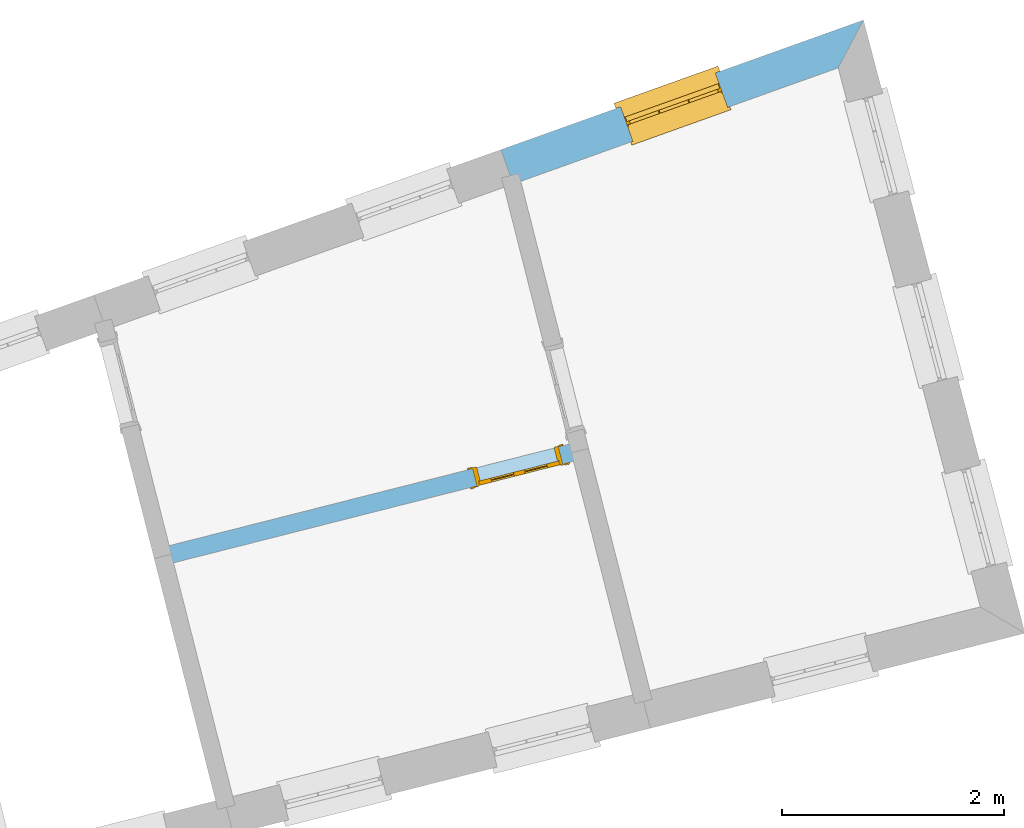
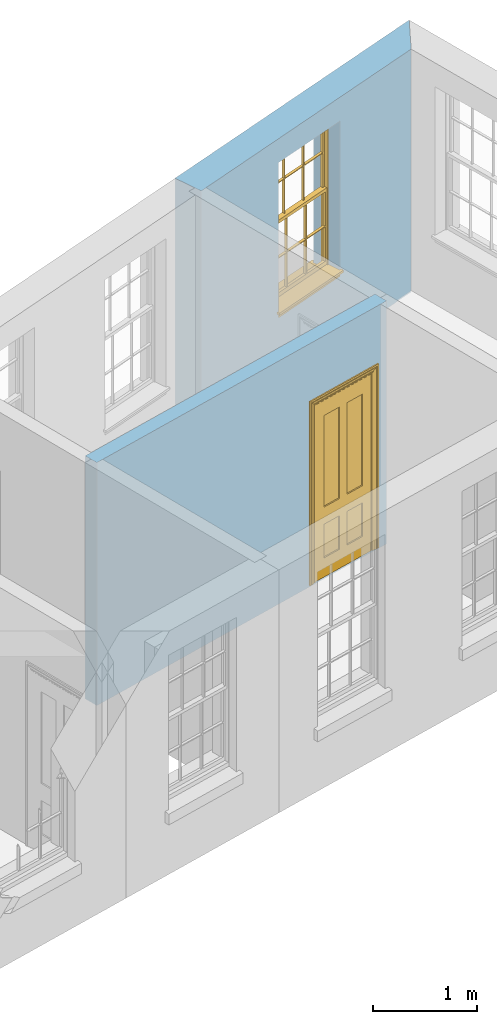
# One storey, part 8 of 11: 1 door, 1 window, 2 openings, plus 2 elements that do not belong to this part.
"""IFC2X3 building model written with IfcOpenShell, lengths in metres."""

from ifc_helpers import new_model, si_unit, frame, origin, place, context, subcontext, project, spatial, polyline, outline, extrude, faceted_brep, material, layer, layer_set, layer_usage, element, fill, save


model = new_model("IFC2X3")

# Units and contexts
model_context = context("Model", 3, world=origin())
body_context = subcontext(model_context, "Body", "Model", "MODEL_VIEW")
ifc_project = project(units=[si_unit("PLANEANGLEUNIT", "RADIAN"), si_unit("MASSUNIT", "GRAM", prefix="KILO"), si_unit("FORCEUNIT", "NEWTON", prefix="KILO"), si_unit("LENGTHUNIT", "METRE")], contexts=[model_context])

# Site, building, storey
site_placement = place(None, origin())
site = spatial("IfcSite", under=ifc_project, at=site_placement, CompositionType="ELEMENT")
building_placement = place(None, origin())
building = spatial("IfcBuilding", under=site, at=building_placement, Name="Building plot-13", CompositionType="ELEMENT")
storey_placement = place(None, frame((0.0, 0.0, 6.7)))
storey = spatial("IfcBuildingStorey", under=building, at=storey_placement, Name="Floor 1", CompositionType="ELEMENT", Elevation=6.7)

# Wall, opening, window
ifc_material_1 = material(Name="Masonry")
ifc_layer_1 = layer(ifc_material_1, 0.33, ventilated=False)
ifc_layer_set_1 = layer_set([ifc_layer_1], Name="My Wall")
ifc_layer_usage_1 = layer_usage(ifc_layer_set_1, "AXIS2", "NEGATIVE", 0.08)
wall_1_placement = place(storey_placement, origin())
wall_1 = element("IfcWallStandardCase", 1, at=wall_1_placement, inside=storey, material=ifc_layer_usage_1, Name="exterior", context=body_context, shape_type="SweptSolid", body=[
    extrude(outline(polyline([(78.699089450727, 52.1144212259562), (78.9265356735152, 52.5462115674965), (75.6540271002417, 51.3760559996695), (75.765136209946, 51.0653233722537), (78.699089450727, 52.1144212259562)])), origin(), (0.0, 0.0, 1.0), 2.85),
])
opening_1_placement = place(storey_placement, frame((0.0, 0.0, 0.75)))
opening_1 = element("IfcOpeningElement", 2, at=opening_1_placement, cuts=wall_1, Name="Opening", ObjectType="Opening", context=body_context, shape_type="SweptSolid", body=[
    extrude(outline(polyline([(77.5904751108561, 52.0684744825221), (76.7336063504065, 51.7620826951557), (76.8447154601108, 51.4513500677399), (77.7015842205604, 51.7577418551063), (77.5904751108561, 52.0684744825221)])), origin(), (0.0, 0.0, 1.0), 1.82),
])
window_placement = place(storey_placement, frame((77.6746486788139, 51.833070976904, 0.75), z_axis=(0.0, 0.0, 1.0), x_axis=(-0.856868760449601, -0.306391787366394, 0.0)))
window = element("IfcWindow", 3, at=window_placement, inside=storey, Name="bedroom outside window", OverallHeight=1.82, OverallWidth=0.91, context=body_context, shape_type="Brep", held_by="IfcProductRepresentation", body=[
    faceted_brep([(0.033125, -0.105, 0.975209), (0.01, -0.105, 0.975209), (0.033125, -0.105, 1.376042), (0.876875, -0.105, 0.975209), (0.876875, -0.105, 1.376042), (0.9, -0.105, 0.975209), (0.876875, -0.105, 1.386042), (0.876875, -0.105, 1.786875), (0.9, -0.105, 1.81), (0.033125, -0.105, 1.786875), (0.033125, -0.105, 1.386042), (0.01, -0.105, 1.81), (0.876875, -0.135, 1.376042), (0.876875, -0.135, 0.975209), (0.9, -0.135, 0.937083), (0.033125, -0.135, 1.786875), (0.01, -0.135, 1.81), (0.033125, -0.135, 1.386042), (0.01, -0.135, 0.937083), (0.033125, -0.135, 0.975209), (0.033125, -0.135, 1.376042), (0.876875, -0.135, 1.786875), (0.876875, -0.135, 1.386042), (0.9, -0.135, 1.81), (0.033125, -0.105, 0.937083), (0.01, -0.105, 0.937083), (0.033125, -0.105, 0.53625), (0.876875, -0.105, 0.937083), (0.876875, -0.105, 0.53625), (0.9, -0.105, 0.937083), (0.876875, -0.105, 0.52625), (0.876875, -0.105, 0.125417), (0.9, -0.105, 0.077167), (0.033125, -0.105, 0.125417), (0.033125, -0.105, 0.52625), (0.01, -0.105, 0.077167), (-0.0425, -0.25, 0.01), (-0.0425, -0.3, 0.001667), (0.0, -0.25, 0.01), (0.9525, -0.25, 0.01), (0.91, -0.25, 0.01), (0.9525, -0.3, 0.001667), (-0.02, 0.08, 0.077167), (0.0, 0.08, 0.077167), (-0.02, 0.11, 0.077167), (0.0, -0.06, 0.077167), (0.01, -0.06, 0.077167), (0.91, -0.06, 0.077167), (0.91, 0.08, 0.077167), (0.9, -0.06, 0.077167), (0.93, 0.08, 0.077167), (0.93, 0.11, 0.077167), (0.01, -0.075, 0.975209), (0.9, -0.075, 0.975209), (0.876875, -0.075, 0.125417), (0.876875, -0.075, 0.52625), (0.9, -0.075, 0.077167), (0.876875, -0.075, 0.53625), (0.876875, -0.075, 0.937083), (0.033125, -0.075, 0.125417), (0.01, -0.075, 0.077167), (0.033125, -0.075, 0.52625), (0.033125, -0.075, 0.937083), (0.033125, -0.075, 0.53625), (-0.02, 0.08, 0.052167), (-0.02, 0.11, 0.052167), (0.93, 0.11, 0.052167), (0.93, 0.08, 0.052167), (0.91, 0.08, 0.052167), (0.0, 0.08, 0.052167), (0.91, -0.15, 0.026667), (0.0, -0.15, 0.026667), (-0.0425, -0.3, -0.123333), (0.9525, -0.3, -0.123333), (-0.0425, -0.25, -0.123333), (0.9525, -0.25, -0.123333), (0.01, -0.06, 1.81), (0.9, -0.06, 1.81), (0.0, -0.06, 1.82), (0.91, -0.06, 1.82), (0.01, -0.15, 0.077167), (0.9, -0.15, 0.077167), (0.592292, -0.105, 0.125417), (0.592292, -0.075, 0.125417), (0.317708, -0.075, 0.125417), (0.317708, -0.105, 0.125417), (0.592292, -0.105, 0.53625), (0.317708, -0.105, 0.53625), (0.317708, -0.105, 0.52625), (0.592292, -0.105, 0.52625), (0.592292, -0.075, 0.53625), (0.317708, -0.075, 0.53625), (0.592292, -0.135, 1.386042), (0.592292, -0.105, 1.386042), (0.317708, -0.105, 1.386042), (0.317708, -0.135, 1.386042), (0.317708, -0.135, 1.376042), (0.592292, -0.135, 1.376042), (0.317708, -0.105, 1.376042), (0.592292, -0.105, 1.376042), (0.602292, -0.135, 1.376042), (0.592292, -0.135, 0.975209), (0.602292, -0.135, 0.975209), (0.602292, -0.105, 0.975209), (0.592292, -0.105, 0.975209), (0.602292, -0.105, 1.376042), (0.602292, -0.075, 0.53625), (0.602292, -0.105, 0.53625), (0.317708, -0.075, 0.52625), (0.307708, -0.075, 0.125417), (0.307708, -0.075, 0.52625), (0.602292, -0.075, 0.52625), (0.602292, -0.075, 0.125417), (0.592292, -0.075, 0.52625), (0.307708, -0.075, 0.53625), (0.317708, -0.075, 0.937083), (0.307708, -0.075, 0.937083), (0.602292, -0.075, 0.937083), (0.592292, -0.075, 0.937083), (0.307708, -0.105, 0.52625), (0.307708, -0.105, 0.125417), (0.307708, -0.105, 0.53625), (0.307708, -0.105, 0.937083), (0.592292, -0.105, 0.937083), (0.317708, -0.105, 0.937083), (0.602292, -0.105, 0.937083), (0.602292, -0.105, 0.52625), (0.602292, -0.105, 0.125417), (0.307708, -0.135, 1.386042), (0.307708, -0.135, 1.376042), (0.307708, -0.135, 0.975209), (0.317708, -0.135, 0.975209), (0.317708, -0.135, 1.786875), (0.307708, -0.135, 1.786875), (0.602292, -0.135, 1.786875), (0.592292, -0.135, 1.786875), (0.602292, -0.135, 1.386042), (0.602292, -0.105, 1.386042), (0.307708, -0.105, 1.386042), (0.307708, -0.105, 1.786875), (0.317708, -0.105, 1.786875), (0.592292, -0.105, 1.786875), (0.602292, -0.105, 1.786875), (0.307708, -0.105, 1.376042), (0.317708, -0.105, 0.975209), (0.307708, -0.105, 0.975209), (0.91, -0.15, 1.82), (0.9, -0.15, 1.81), (0.01, -0.15, 1.81), (0.0, -0.15, 1.82), (0.91, -0.25, 0.0), (0.0, -0.25, 0.0), (0.91, 0.08, 0.0), (0.0, 0.08, 0.0)], [[[0, 1, 2]], [[3, 4, 5]], [[6, 7, 8]], [[9, 10, 11]], [[12, 13, 14]], [[15, 16, 17]], [[18, 19, 20]], [[21, 22, 23]], [[24, 25, 26]], [[27, 28, 29]], [[30, 31, 32]], [[33, 34, 35]], [[14, 27, 29]], [[25, 24, 18]], [[36, 37, 38]], [[39, 40, 41]], [[42, 43, 44]], [[45, 46, 43]], [[47, 48, 49]], [[50, 51, 48]], [[1, 0, 52]], [[5, 53, 3]], [[54, 55, 56]], [[57, 58, 53]], [[59, 60, 61]], [[62, 63, 52]], [[48, 43, 46, 49]], [[51, 44, 43, 48]], [[64, 42, 44, 65]], [[65, 44, 51, 66]], [[66, 51, 50, 67]], [[65, 66, 68, 69]], [[60, 56, 49, 46]], [[70, 71, 38, 40]], [[37, 41, 40, 38]], [[37, 72, 73, 41]], [[74, 75, 73, 72]], [[8, 11, 76, 77]], [[76, 78, 79, 77]], [[32, 35, 80, 81]], [[81, 80, 71, 70]], [[82, 83, 84, 85]], [[86, 87, 88, 89]], [[86, 90, 91, 87]], [[92, 93, 94, 95]], [[92, 95, 96, 97]], [[96, 98, 99, 97]], [[100, 97, 101, 102]], [[103, 104, 99, 105]], [[97, 99, 104, 101]], [[102, 103, 105, 100]], [[28, 57, 106, 107]], [[108, 84, 109, 110]], [[111, 112, 83, 113]], [[114, 110, 61, 63]], [[90, 113, 108, 91]], [[115, 91, 114, 116]], [[117, 106, 90, 118]], [[111, 106, 57, 55]], [[119, 110, 109, 120]], [[34, 61, 110, 119]], [[89, 113, 83, 82]], [[88, 108, 113, 89]], [[85, 84, 108, 88]], [[121, 114, 63, 26]], [[122, 116, 114, 121]], [[123, 118, 90, 86]], [[87, 91, 115, 124]], [[107, 106, 117, 125]], [[126, 111, 55, 30]], [[127, 112, 111, 126]], [[126, 30, 28, 107]], [[88, 119, 120, 85]], [[126, 89, 82, 127]], [[125, 123, 86, 107]], [[121, 26, 34, 119]], [[124, 122, 121, 87]], [[128, 17, 20, 129]], [[96, 129, 130, 131]], [[132, 133, 128, 95]], [[134, 135, 92, 136]], [[100, 12, 22, 136]], [[137, 6, 4, 105]], [[94, 138, 139, 140]], [[137, 93, 141, 142]], [[99, 98, 94, 93]], [[143, 2, 10, 138]], [[144, 145, 143, 98]], [[129, 143, 145, 130]], [[20, 2, 143, 129]], [[131, 144, 98, 96]], [[128, 138, 10, 17]], [[133, 139, 138, 128]], [[135, 141, 93, 92]], [[95, 94, 140, 132]], [[22, 6, 137, 136]], [[136, 137, 142, 134]], [[100, 105, 4, 12]], [[107, 86, 89, 126]], [[106, 111, 113, 90]], [[91, 108, 110, 114]], [[87, 121, 119, 88]], [[97, 100, 136, 92]], [[129, 96, 95, 128]], [[98, 143, 138, 94]], [[105, 99, 93, 137]], [[131, 101, 104, 144]], [[124, 115, 118, 123]], [[132, 140, 141, 135]], [[120, 109, 59, 33]], [[15, 9, 139, 133]], [[134, 142, 7, 21]], [[31, 54, 112, 127]], [[36, 74, 72, 37]], [[39, 41, 73, 75]], [[18, 14, 101, 131]], [[23, 16, 132, 135]], [[83, 56, 60, 84]], [[52, 53, 118, 115]], [[53, 52, 144, 104]], [[11, 8, 141, 140]], [[14, 18, 124, 123]], [[2, 1, 11, 10]], [[8, 5, 4, 6]], [[57, 53, 56, 55]], [[60, 52, 63, 61]], [[26, 25, 35, 34]], [[32, 29, 28, 30]], [[14, 23, 22, 12]], [[18, 20, 17, 16]], [[19, 0, 2, 20]], [[17, 10, 9, 15]], [[12, 4, 3, 13]], [[21, 7, 6, 22]], [[27, 58, 57, 28]], [[30, 55, 54, 31]], [[33, 59, 61, 34]], [[26, 63, 62, 24]], [[5, 8, 77, 53]], [[76, 11, 1, 52]], [[46, 45, 78, 76]], [[49, 77, 79, 47]], [[70, 146, 147, 81]], [[71, 80, 148, 149]], [[19, 130, 145, 0]], [[102, 13, 3, 103]], [[116, 122, 24, 62]], [[29, 32, 81, 14]], [[80, 35, 25, 18]], [[60, 46, 76, 52]], [[77, 49, 56, 53]], [[23, 14, 81, 147]], [[16, 148, 80, 18]], [[35, 85, 120]], [[120, 33, 35]], [[127, 82, 32]], [[32, 31, 127]], [[32, 82, 85, 35]], [[102, 101, 14]], [[14, 13, 102]], [[18, 131, 130]], [[130, 19, 18]], [[134, 21, 23]], [[23, 135, 134]], [[16, 15, 133]], [[133, 132, 16]], [[11, 140, 139]], [[139, 9, 11]], [[142, 141, 8]], [[8, 7, 142]], [[23, 147, 148, 16]], [[146, 149, 148, 147]], [[52, 115, 116]], [[116, 62, 52]], [[118, 53, 117]], [[58, 117, 53]], [[27, 125, 117, 58]], [[56, 83, 112]], [[112, 54, 56]], [[109, 84, 60]], [[60, 59, 109]], [[125, 27, 14]], [[14, 123, 125]], [[122, 124, 18]], [[18, 24, 122]], [[145, 144, 52]], [[52, 0, 145]], [[103, 3, 53]], [[53, 104, 103]], [[79, 78, 149, 146]], [[78, 45, 71, 149]], [[146, 70, 47, 79]], [[150, 75, 74, 151]], [[68, 66, 67]], [[48, 68, 67, 50]], [[69, 64, 65]], [[42, 64, 69, 43]], [[69, 68, 152, 153]], [[70, 68, 48, 47]], [[150, 152, 68, 70]], [[43, 69, 71, 45]], [[69, 153, 151, 71]], [[152, 150, 151, 153]], [[38, 151, 74, 36]], [[71, 151, 38]], [[39, 75, 150, 40]], [[40, 150, 70]]]),
])
fill(opening_1, window)

# Wall, opening, door
ifc_material_2 = material(Name="Masonry")
ifc_layer_2 = layer(ifc_material_2, 0.16, ventilated=False)
ifc_layer_set_2 = layer_set([ifc_layer_2], Name="My Wall")
ifc_layer_usage_2 = layer_usage(ifc_layer_set_2, "AXIS2", "NEGATIVE", 0.08)
wall_2_placement = place(storey_placement, origin())
wall_2 = element("IfcWallStandardCase", 4, at=wall_2_placement, inside=storey, material=ifc_layer_usage_2, Name="interior", context=body_context, shape_type="SweptSolid", body=[
    extrude(outline(polyline([(76.3872594352377, 48.5815460629626), (76.3479245240301, 48.736635600844), (72.5821025731174, 47.7815210645155), (72.621437484325, 47.6264315266341), (76.3872594352377, 48.5815460629626)])), origin(), (0.0, 0.0, 1.0), 2.85),
])
opening_2_placement = place(storey_placement, frame((0.0, 0.0, 0.0199999999999996)))
opening_2 = element("IfcOpeningElement", 5, at=opening_2_placement, cuts=wall_2, Name="Opening", ObjectType="Opening", context=body_context, shape_type="SweptSolid", body=[
    extrude(outline(polyline([(76.1734487939134, 48.6923838257354), (75.3980011045061, 48.495709269697), (75.4373360157138, 48.3406197318156), (76.2127837051211, 48.5372942878539), (76.1734487939134, 48.6923838257354)])), origin(), (0.0, 0.0, 1.0), 2.1),
])
door_placement = place(storey_placement, frame((76.1931162495173, 48.6148390567947, 0.0199999999999996), z_axis=(0.0, 0.0, 1.0), x_axis=(-0.775447689407301, -0.19667455603836, 0.0)))
door = element("IfcDoor", 6, at=door_placement, inside=storey, Name="toilet inside door", OverallHeight=2.1, OverallWidth=0.8, context=body_context, shape_type="Brep", held_by="IfcProductRepresentation", body=[
    faceted_brep([(0.773, 0.08, 1.895), (0.66, 0.08, 1.895), (0.66, 0.08, 2.073), (0.773, 0.08, 2.073), (0.773, 0.08, 0.82), (0.66, 0.08, 0.82), (0.45, 0.08, 1.895), (0.45, 0.08, 2.073), (0.773, 0.08, 0.62), (0.66, 0.08, 0.62), (0.66, 0.065, 0.82), (0.66, 0.065, 1.895), (0.45, 0.065, 1.895), (0.35, 0.08, 1.895), (0.35, 0.08, 2.073), (0.773, 0.08, 0.225), (0.66, 0.08, 0.225), (0.45, 0.08, 0.62), (0.45, 0.08, 0.82), (0.45, 0.065, 0.82), (0.35, 0.08, 0.82), (0.14, 0.08, 2.073), (0.14, 0.08, 1.895), (0.773, 0.08, 0.0), (0.66, 0.08, 0.0), (0.66, 0.065, 0.225), (0.66, 0.065, 0.62), (0.45, 0.065, 0.62), (0.35, 0.08, 0.62), (0.35, 0.065, 0.82), (0.35, 0.065, 1.895), (0.14, 0.065, 1.895), (0.027, 0.08, 2.073), (0.027, 0.08, 1.895), (0.773, 0.042, 0.0), (0.66, 0.042, 0.0), (0.45, 0.08, 0.0), (0.45, 0.08, 0.225), (0.45, 0.065, 0.225), (0.35, 0.08, 0.225), (0.14, 0.08, 0.82), (0.14, 0.08, 0.62), (0.14, 0.065, 0.82), (0.027, 0.08, 0.82), (0.773, 0.042, 0.225), (0.66, 0.042, 0.225), (0.45, 0.042, 0.0), (0.35, 0.08, 0.0), (0.35, 0.065, 0.225), (0.35, 0.065, 0.62), (0.14, 0.065, 0.62), (0.027, 0.08, 0.62), (0.773, 0.042, 0.62), (0.66, 0.042, 0.62), (0.45, 0.042, 0.225), (0.35, 0.042, 0.0), (0.14, 0.08, 0.225), (0.14, 0.08, 0.0), (0.14, 0.065, 0.225), (0.027, 0.08, 0.225), (0.773, 0.042, 0.82), (0.66, 0.042, 0.82), (0.66, 0.057, 0.62), (0.66, 0.057, 0.225), (0.45, 0.057, 0.225), (0.35, 0.042, 0.225), (0.14, 0.042, 0.0), (0.027, 0.08, 0.0), (0.773, 0.042, 1.895), (0.66, 0.042, 1.895), (0.45, 0.042, 0.62), (0.45, 0.042, 0.82), (0.45, 0.057, 0.62), (0.35, 0.042, 0.62), (0.14, 0.042, 0.225), (0.027, 0.042, 0.0), (0.773, 0.042, 2.073), (0.66, 0.042, 2.073), (0.66, 0.057, 1.895), (0.66, 0.057, 0.82), (0.45, 0.057, 0.82), (0.35, 0.042, 0.82), (0.35, 0.057, 0.62), (0.35, 0.057, 0.225), (0.14, 0.057, 0.225), (0.027, 0.042, 0.225), (0.45, 0.042, 1.895), (0.45, 0.042, 2.073), (0.45, 0.057, 1.895), (0.35, 0.042, 1.895), (0.14, 0.042, 0.82), (0.14, 0.042, 0.62), (0.14, 0.057, 0.62), (0.027, 0.042, 0.62), (0.35, 0.042, 2.073), (0.35, 0.057, 1.895), (0.35, 0.057, 0.82), (0.14, 0.057, 0.82), (0.027, 0.042, 0.82), (0.14, 0.042, 2.073), (0.14, 0.042, 1.895), (0.14, 0.057, 1.895), (0.027, 0.042, 1.895), (0.027, 0.042, 2.073), (0.02, 0.085, 0.0), (0.005, 0.09, 0.0), (0.005, 0.09, 2.095), (0.02, 0.085, 2.08), (0.02, 0.08, 0.0), (0.0, 0.085, 0.0), (0.0, 0.085, 2.1), (0.795, 0.09, 2.095), (0.78, 0.085, 2.08), (0.02, 0.08, 2.08), (0.0, 0.08, 0.0), (-0.032, 0.095, 0.0), (-0.032, 0.095, 2.132), (0.8, 0.085, 2.1), (0.795, 0.09, 0.0), (0.78, 0.085, 0.0), (0.78, 0.08, 2.08), (0.04, 0.04, 0.0), (0.025, 0.04, 0.0), (0.025, 0.04, 2.075), (0.04, 0.04, 2.06), (-0.04, 0.09, 0.0), (-0.04, 0.09, 2.14), (0.832, 0.095, 2.132), (0.8, 0.085, 0.0), (0.78, 0.08, 0.0), (0.8, 0.08, 0.0), (0.86, 0.08, 0.0), (0.86, 0.08, 2.16), (0.8, 0.08, 2.1), (-0.06, 0.08, 2.16), (0.0, 0.08, 2.1), (-0.06, 0.08, 0.0), (-0.04, 0.095, 0.0), (-0.04, 0.095, 2.14), (0.84, 0.09, 2.14), (0.832, 0.095, 0.0), (0.84, 0.09, 0.0), (0.86, 0.095, 0.0), (0.86, 0.095, 2.16), (-0.06, 0.095, 2.16), (-0.06, 0.095, 0.0), (0.84, 0.095, 0.0), (0.84, 0.095, 2.14), (-0.025, -0.095, 0.0), (-0.025, -0.09, 0.0), (-0.025, -0.09, 2.125), (-0.025, -0.095, 2.125), (-0.017, -0.095, 0.0), (-0.017, -0.095, 2.117), (0.825, -0.09, 2.125), (0.825, -0.095, 2.125), (0.825, -0.095, 0.0), (0.845, -0.095, 0.0), (-0.045, -0.095, 2.145), (-0.045, -0.095, 0.0), (0.845, -0.095, 2.145), (0.015, -0.085, 0.0), (0.015, -0.085, 2.085), (0.817, -0.095, 2.117), (0.825, -0.09, 0.0), (0.845, -0.08, 0.0), (0.845, -0.08, 2.145), (-0.045, -0.08, 2.145), (-0.045, -0.08, 0.0), (0.02, -0.09, 0.0), (0.02, -0.09, 2.08), (0.785, -0.085, 2.085), (0.817, -0.095, 0.0), (0.8, -0.08, 0.0), (0.8, -0.08, 2.1), (0.0, -0.08, 2.1), (0.0, -0.08, 0.0), (0.035, -0.085, 0.0), (0.035, -0.085, 2.065), (0.78, -0.09, 2.08), (0.785, -0.085, 0.0), (0.775, 0.04, 2.075), (0.76, 0.04, 2.06), (0.035, -0.08, 2.065), (0.035, -0.08, 0.0), (0.765, -0.085, 2.065), (0.78, -0.09, 0.0), (0.765, -0.08, 0.0), (0.765, -0.08, 2.065), (0.765, -0.085, 0.0), (0.04, -0.08, 2.06), (0.04, -0.08, 0.0), (0.76, -0.08, 2.06), (0.76, -0.08, 0.0), (0.76, 0.04, 0.0), (0.775, 0.04, 0.0), (0.025, 0.08, 0.0), (0.025, 0.08, 2.075), (0.775, 0.08, 0.0), (0.775, 0.08, 2.075)], [[[0, 1, 2, 3]], [[1, 0, 4, 5]], [[1, 6, 7, 2]], [[8, 9, 5, 4]], [[1, 5, 10, 11]], [[6, 1, 11, 12]], [[6, 13, 14, 7]], [[15, 16, 9, 8]], [[9, 17, 18, 5]], [[5, 18, 19, 10]], [[10, 19, 12, 11]], [[18, 6, 12, 19]], [[18, 20, 13, 6]], [[21, 14, 13, 22]], [[23, 24, 16, 15]], [[9, 16, 25, 26]], [[17, 9, 26, 27]], [[17, 28, 20, 18]], [[13, 20, 29, 30]], [[22, 13, 30, 31]], [[32, 21, 22, 33]], [[34, 35, 24, 23]], [[24, 36, 37, 16]], [[16, 37, 38, 25]], [[25, 38, 27, 26]], [[37, 17, 27, 38]], [[37, 39, 28, 17]], [[40, 20, 28, 41]], [[20, 40, 42, 29]], [[31, 30, 29, 42]], [[40, 22, 31, 42]], [[33, 22, 40, 43]], [[35, 34, 44, 45]], [[35, 46, 36, 24]], [[36, 47, 39, 37]], [[28, 39, 48, 49]], [[41, 28, 49, 50]], [[43, 40, 41, 51]], [[45, 44, 52, 53]], [[46, 35, 45, 54]], [[46, 55, 47, 36]], [[56, 39, 47, 57]], [[39, 56, 58, 48]], [[50, 49, 48, 58]], [[56, 41, 50, 58]], [[51, 41, 56, 59]], [[53, 52, 60, 61]], [[45, 53, 62, 63]], [[54, 45, 63, 64]], [[55, 46, 54, 65]], [[55, 66, 57, 47]], [[59, 56, 57, 67]], [[61, 60, 68, 69]], [[70, 53, 61, 71]], [[53, 70, 72, 62]], [[72, 64, 63, 62]], [[70, 54, 64, 72]], [[65, 54, 70, 73]], [[65, 74, 66, 55]], [[67, 57, 66, 75]], [[69, 68, 76, 77]], [[61, 69, 78, 79]], [[71, 61, 79, 80]], [[73, 70, 71, 81]], [[65, 73, 82, 83]], [[74, 65, 83, 84]], [[74, 85, 75, 66]], [[86, 69, 77, 87]], [[69, 86, 88, 78]], [[88, 80, 79, 78]], [[86, 71, 80, 88]], [[81, 71, 86, 89]], [[73, 81, 90, 91]], [[73, 91, 92, 82]], [[83, 82, 92, 84]], [[91, 74, 84, 92]], [[91, 93, 85, 74]], [[89, 86, 87, 94]], [[81, 89, 95, 96]], [[90, 81, 96, 97]], [[90, 98, 93, 91]], [[94, 99, 100, 89]], [[89, 100, 101, 95]], [[101, 97, 96, 95]], [[100, 90, 97, 101]], [[100, 102, 98, 90]], [[99, 103, 102, 100]], [[32, 103, 99, 21]], [[102, 103, 32, 33]], [[98, 102, 33, 43]], [[21, 99, 94, 14]], [[94, 87, 7, 14]], [[7, 87, 77, 2]], [[76, 3, 2, 77]], [[43, 51, 93, 98]], [[51, 59, 85, 93]], [[67, 75, 85, 59]], [[34, 23, 15, 44]], [[44, 15, 8, 52]], [[52, 8, 4, 60]], [[0, 68, 60, 4]], [[0, 3, 76, 68]], [[104, 105, 106, 107]], [[104, 108, 109, 105]], [[105, 109, 110, 106]], [[107, 106, 111, 112]], [[107, 113, 108, 104]], [[114, 109, 108]], [[109, 115, 116, 110]], [[106, 110, 117, 111]], [[112, 111, 118, 119]], [[113, 107, 112, 120]], [[121, 122, 123, 124]], [[115, 109, 114, 125]], [[115, 125, 126, 116]], [[110, 116, 127, 117]], [[111, 117, 128, 118]], [[118, 128, 129, 119]], [[120, 112, 119, 129]], [[130, 129, 128]], [[130, 131, 132, 133]], [[133, 132, 134, 135]], [[135, 134, 136, 114]], [[136, 125, 114]], [[125, 137, 138, 126]], [[116, 126, 139, 127]], [[117, 127, 140, 128]], [[141, 130, 128, 140]], [[131, 130, 141]], [[131, 142, 143, 132]], [[132, 143, 144, 134]], [[134, 144, 145, 136]], [[137, 125, 136, 145]], [[143, 142, 146]], [[143, 146, 147]], [[137, 145, 144]], [[143, 147, 138]], [[138, 137, 144]], [[143, 138, 144]], [[126, 138, 147, 139]], [[127, 139, 141, 140]], [[142, 131, 141, 146]], [[139, 147, 146, 141]], [[148, 149, 150, 151]], [[149, 152, 153, 150]], [[151, 150, 154, 155]], [[155, 156, 157]], [[158, 159, 148]], [[158, 148, 151]], [[155, 157, 160]], [[158, 151, 155]], [[155, 160, 158]], [[152, 161, 162, 153]], [[150, 153, 163, 154]], [[155, 154, 164, 156]], [[156, 164, 165, 157]], [[157, 165, 166, 160]], [[160, 166, 167, 158]], [[158, 167, 168, 159]], [[161, 169, 170, 162]], [[153, 162, 171, 163]], [[154, 163, 172, 164]], [[165, 164, 173]], [[165, 173, 174, 166]], [[166, 174, 175, 167]], [[167, 175, 176, 168]], [[169, 177, 178, 170]], [[162, 170, 179, 171]], [[163, 171, 180, 172]], [[172, 180, 173, 164]], [[124, 123, 181, 182]], [[183, 178, 177, 184]], [[170, 178, 185, 179]], [[171, 179, 186, 180]], [[187, 173, 180]], [[185, 188, 187, 189]], [[188, 185, 178, 183]], [[179, 185, 189, 186]], [[189, 187, 180, 186]], [[190, 183, 184, 191]], [[192, 188, 183, 190]], [[191, 184, 122, 121]], [[124, 190, 191, 121]], [[193, 187, 188, 192]], [[182, 192, 190, 124]], [[184, 176, 122]], [[194, 195, 187, 193]], [[192, 182, 194, 193]], [[161, 176, 184]], [[114, 108, 122, 176]], [[173, 187, 195]], [[152, 149, 176, 161]], [[169, 161, 184, 177]], [[196, 122, 108]], [[176, 175, 135, 114]], [[173, 195, 129, 130]], [[176, 149, 168]], [[123, 122, 196, 197]], [[196, 108, 113, 197]], [[175, 174, 133, 135]], [[198, 129, 195]], [[133, 174, 173, 130]], [[159, 168, 149, 148]], [[181, 123, 197, 199]], [[197, 113, 120, 199]], [[199, 120, 129, 198]], [[195, 181, 199, 198]], [[195, 194, 182, 181]]]),
])
fill(opening_2, door)

save(model, "model.ifc")
